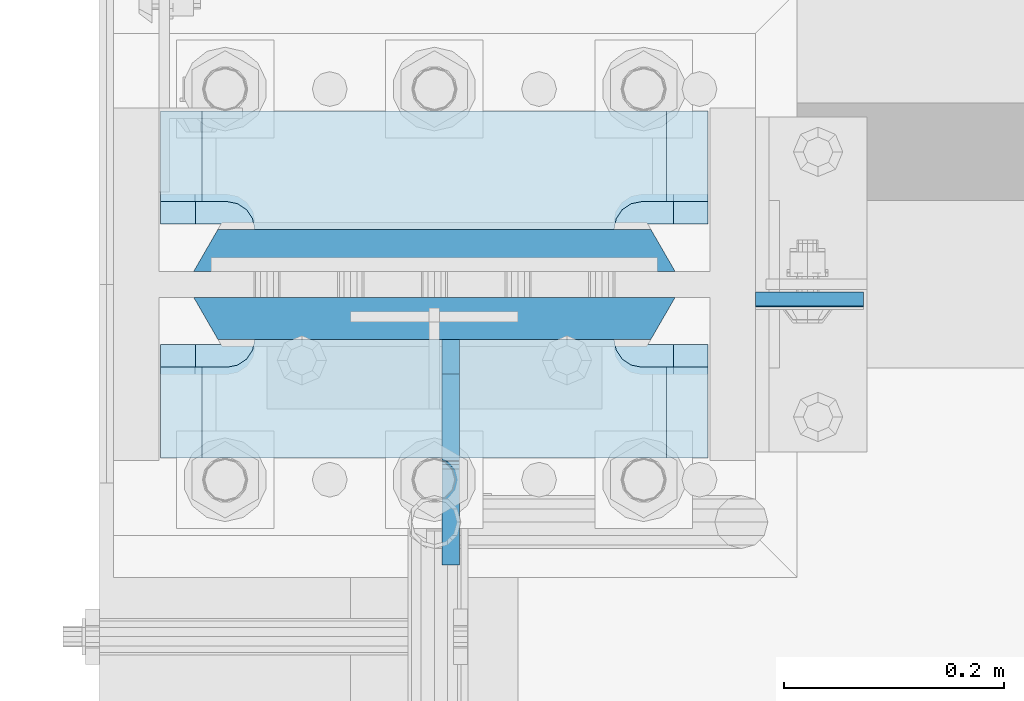
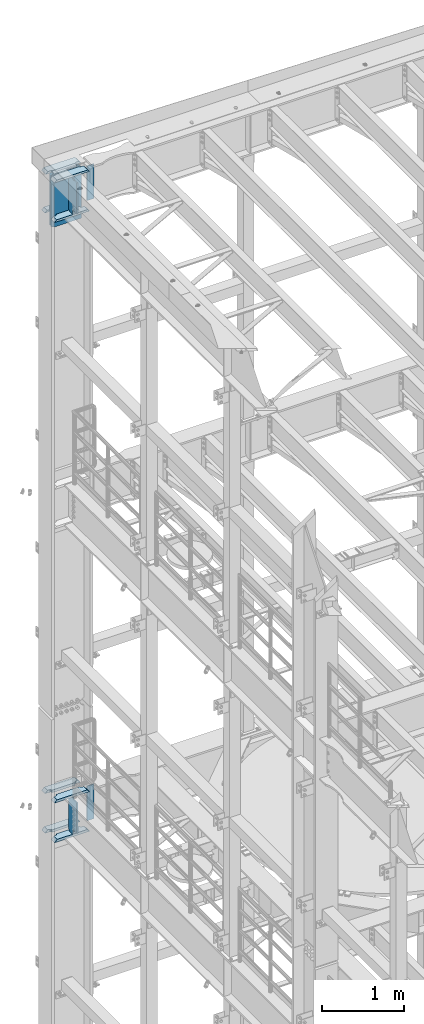
# One storey, part 1772 of 1876: 14 plates, 2 elements without a shape of their own.
"""IFC2X3 building model written with IfcOpenShell, lengths in millimetres."""

import ifcopenshell
import ifcopenshell.guid

model = None  # the IFC model being written
_history = None  # IfcOwnerHistory: only IFC2X3 demands one
_inside = {}  # id of a spatial element -> (the spatial element, [elements in it])
_under = {}  # id of a project, library or spatial element -> (it, [spatial elements below it])
_declared = {}  # id of a project -> (the project, [libraries it declares])
_typed = {}  # id of a type object -> (the type object, [elements of that type])
_made_of = {}  # id of a material, layer set ... -> (it, [elements and type objects made of it])


def new_model(schema):
    """Start an empty IFC model of exactly this schema.

    Asked for "IFC4X3", IfcOpenShell would pick the latest addendum, in which some entities
    have other attributes; the version numbers below select the first issue.
    IFC2X3 requires an IfcOwnerHistory on every rooted entity: one is made here for all.
    """
    global model, _history
    if schema == "IFC4X3":
        model = ifcopenshell.file(schema_version=(4, 3, 0, 0))
    else:
        model = ifcopenshell.file(schema=schema)
    _inside.clear()
    _under.clear()
    _declared.clear()
    _typed.clear()
    _made_of.clear()
    _history = None
    if model.schema == "IFC2X3":
        org = make("IfcOrganization", Name="unknown")
        user = make(
            "IfcPersonAndOrganization",
            ThePerson=make("IfcPerson", FamilyName="unknown"),
            TheOrganization=org,
        )
        app = make(
            "IfcApplication",
            ApplicationDeveloper=org,
            Version="unknown",
            ApplicationFullName="unknown",
            ApplicationIdentifier="unknown",
        )
        _history = make(
            "IfcOwnerHistory",
            OwningUser=user,
            OwningApplication=app,
            ChangeAction="ADDED",
            CreationDate=0,
        )
    return model


def make(cls, **values):
    """One entity of the class cls with the attributes given. An attribute that is None is left unset."""
    return model.create_entity(
        cls, **{name: value for name, value in values.items() if value is not None}
    )


def rooted(cls, **values):
    """An entity with a GlobalId (a new one), such as an element, a storey or a relation."""
    return make(cls, GlobalId=ifcopenshell.guid.new(), OwnerHistory=_history, **values)


def si_unit(unit_type, name, prefix=None):
    """IfcSIUnit, for example si_unit("LENGTHUNIT", "METRE", prefix="MILLI")."""
    return make("IfcSIUnit", UnitType=unit_type, Prefix=prefix, Name=name)


def assignment(units):
    """IfcUnitAssignment: the units of a project."""
    return None if units is None else make("IfcUnitAssignment", Units=units)


def point(xyz):
    """IfcCartesianPoint."""
    return None if xyz is None else make("IfcCartesianPoint", Coordinates=xyz)


def direction(xyz):
    """IfcDirection."""
    return None if xyz is None else make("IfcDirection", DirectionRatios=xyz)


def frame(location, z_axis=None, x_axis=None):
    """IfcAxis2Placement3D, a coordinate frame: its origin and axes. An axis left out is left unset."""
    return make(
        "IfcAxis2Placement3D",
        Location=point(location),
        Axis=direction(z_axis),
        RefDirection=direction(x_axis),
    )


def origin_with_axes():
    """The frame at (0, 0, 0) with the z axis (0, 0, 1) and the x axis (1, 0, 0) written out."""
    return frame((0.0, 0.0, 0.0), z_axis=(0.0, 0.0, 1.0), x_axis=(1.0, 0.0, 0.0))


def place(relative_to, where):
    """IfcLocalPlacement: puts the frame where relative to a parent placement (None: the world)."""
    return make(
        "IfcLocalPlacement", PlacementRelTo=relative_to, RelativePlacement=where
    )


def context(
    kind, dimensions, precision=None, world=None, true_north=None, identifier=None
):
    """IfcGeometricRepresentationContext, for example the 3D "Model" context."""
    return make(
        "IfcGeometricRepresentationContext",
        ContextIdentifier=identifier,
        ContextType=kind,
        CoordinateSpaceDimension=dimensions,
        Precision=precision,
        WorldCoordinateSystem=world,
        TrueNorth=true_north,
    )


def subcontext(parent, identifier, kind, view, scale=None):
    """IfcGeometricRepresentationSubContext, for example "Body" below "Model"."""
    return make(
        "IfcGeometricRepresentationSubContext",
        ContextIdentifier=identifier,
        ContextType=kind,
        ParentContext=parent,
        TargetScale=scale,
        TargetView=view,
    )


def project(units=None, contexts=None):
    """IfcProject with its units and contexts."""
    return rooted(
        "IfcProject",
        Name="project",
        RepresentationContexts=contexts,
        UnitsInContext=assignment(units),
    )


def spatial(cls, under=None, at=None, **own):
    """A site, building, storey or space (cls), placed at a placement, below another one or the project."""
    s = rooted(cls, ObjectPlacement=at, **own)
    if under is not None:
        _under.setdefault(under.id(), (under, []))[1].append(s)
    return s


def faces_of(points, faces, orient=None, outer=None):
    """IfcFace entities. A face is a list of loops; a loop is a list of indices into points, from 0.

    orient and outer hold one flag for each loop. By default every Orientation is true, the
    first loop of a face is its IfcFaceOuterBound and the others are IfcFaceBound.
    """
    made = []
    for i, loops in enumerate(faces):
        bounds = []
        for j, loop in enumerate(loops):
            is_outer = j == 0 if outer is None else outer[i][j]
            bounds.append(
                make(
                    "IfcFaceOuterBound" if is_outer else "IfcFaceBound",
                    Bound=make("IfcPolyLoop", Polygon=[points[k] for k in loop]),
                    Orientation=True if orient is None else orient[i][j],
                )
            )
        made.append(make("IfcFace", Bounds=bounds))
    return made


def faceted_brep(points, faces, orient=None, outer=None, voids=None):
    """IfcFacetedBrep: a solid bounded by flat faces; with voids (closed shells), ...WithVoids."""
    shared = [point(p) for p in points]
    hull = make("IfcClosedShell", CfsFaces=faces_of(shared, faces, orient, outer))
    if voids is None:
        return make("IfcFacetedBrep", Outer=hull)
    return make(
        "IfcFacetedBrepWithVoids",
        Outer=hull,
        Voids=[
            make(cls, CfsFaces=faces_of(shared, fs, o, b)) for cls, fs, o, b in voids
        ],
    )


def shape(context_of_items, identifier, shape_type, items):
    """IfcShapeRepresentation: the items that make up one representation, for example the "Body"."""
    return make(
        "IfcShapeRepresentation",
        ContextOfItems=context_of_items,
        RepresentationIdentifier=identifier,
        RepresentationType=shape_type,
        Items=items,
    )


def material(Name=None, Category=None):
    """IfcMaterial."""
    return make("IfcMaterial", Name=Name, Category=Category)


def made_of(thing, what):
    """Note that an element or type object is made of a material, layer set ...; save() writes the relation."""
    if what is not None:
        _made_of.setdefault(what.id(), (what, []))[1].append(thing)
    return thing


def type_object(cls, material=None, **own):
    """A type object (cls), such as IfcWallType, which elements share."""
    return made_of(rooted(cls, **own), material)


def element(
    cls,
    number,
    at=None,
    inside=None,
    cuts=None,
    type_object=None,
    material=None,
    context=None,
    identifier="Body",
    shape_type=None,
    held_by="IfcProductDefinitionShape",
    body=None,
    shapes=None,
    **own,
):
    """One element of the class cls, such as IfcWall. Its Tag is "e" and its number.

    at: its placement. inside: the storey or other place that contains it. cuts: it is an
    opening in that element (IfcRelVoidsElement). A single representation is given by context,
    identifier, shape_type and body (its items); several are given by shapes. held_by: the class
    of the entity that holds the representations. save() writes the other relations.
    """
    e = rooted(cls, Tag="e%d" % number, ObjectPlacement=at, **own)
    if body is not None:
        shapes = [shape(context, identifier, shape_type, body)]
    if shapes is not None:
        e.Representation = make(held_by, Representations=shapes)
    if inside is not None:
        _inside.setdefault(inside.id(), (inside, []))[1].append(e)
    if cuts is not None:
        rooted(
            "IfcRelVoidsElement", RelatingBuildingElement=cuts, RelatedOpeningElement=e
        )
    if type_object is not None:
        _typed.setdefault(type_object.id(), (type_object, []))[1].append(e)
    return made_of(e, material)


def aggregate(whole, parts):
    """IfcRelAggregates: a whole, such as a stair, and the parts it consists of."""
    return rooted("IfcRelAggregates", RelatingObject=whole, RelatedObjects=parts)


def save(model, path):
    """Write the relations noted so far, then the file.

    IfcRelAggregates (storeys below a building ...), IfcRelContainedInSpatialStructure (elements
    in a storey), IfcRelDefinesByType, IfcRelAssociatesMaterial and IfcRelDeclares: one each for
    every whole, place, type object, material and project.
    """
    for whole, parts in _under.values():
        aggregate(whole, parts)
    for where, things in _inside.values():
        rooted(
            "IfcRelContainedInSpatialStructure",
            RelatedElements=things,
            RelatingStructure=where,
        )
    for kind, things in _typed.values():
        rooted("IfcRelDefinesByType", RelatedObjects=things, RelatingType=kind)
    for what, things in _made_of.values():
        rooted("IfcRelAssociatesMaterial", RelatedObjects=things, RelatingMaterial=what)
    for by, libraries in _declared.values():
        rooted("IfcRelDeclares", RelatingContext=by, RelatedDefinitions=libraries)
    model.write(path)


model = new_model("IFC2X3")

# Units and contexts
model_context = context("Model", 3, precision=1e-05, world=origin_with_axes())
body_context = subcontext(model_context, "Body", "Model", "MODEL_VIEW")
ifc_project = project(units=[si_unit("LENGTHUNIT", "METRE", prefix="MILLI"), si_unit("AREAUNIT", "SQUARE_METRE"), si_unit("VOLUMEUNIT", "CUBIC_METRE"), si_unit("MASSUNIT", "GRAM", prefix="KILO"), si_unit("TIMEUNIT", "SECOND"), si_unit("PLANEANGLEUNIT", "RADIAN"), si_unit("SOLIDANGLEUNIT", "STERADIAN"), si_unit("THERMODYNAMICTEMPERATUREUNIT", "DEGREE_CELSIUS"), si_unit("LUMINOUSINTENSITYUNIT", "LUMEN")], contexts=[model_context])

# Site, building, storey
site_placement = place(None, origin_with_axes())
site = spatial("IfcSite", under=ifc_project, at=site_placement, CompositionType="ELEMENT")
building_placement = place(site_placement, origin_with_axes())
building = spatial("IfcBuilding", under=site, at=building_placement, Name="Undefined", CompositionType="ELEMENT")
storey_placement = place(building_placement, origin_with_axes())
storey = spatial("IfcBuildingStorey", under=building, at=storey_placement, Name="Undefined", CompositionType="ELEMENT", Elevation=0.0)

# Assembly, plate
assembly_1_placement = place(storey_placement, origin_with_axes())
assembly_1 = element("IfcElementAssembly", 1, at=assembly_1_placement, inside=storey, Name="COLUMN", AssemblyPlace="NOTDEFINED", PredefinedType="RIGID_FRAME")
ifc_material_1 = material(Name="STEEL/A572-50")
plate_type_1 = type_object("IfcPlateType", PredefinedType="NOTDEFINED")
plate_1_placement = place(assembly_1_placement, frame((292.1, 13702.5069998741, 22501.225), z_axis=(1.0, 0.0, 0.0), x_axis=(0.0, 0.0, -1.0)))
plate_1 = element("IfcPlate", 2, at=plate_1_placement, type_object=plate_type_1, material=ifc_material_1, Name="PLATE", context=body_context, shape_type="Brep", body=[
    faceted_brep([(0.0, -6.35000000000036, 0.0), (0.0, -6.34999999999991, 98.4250030517578), (0.0, 6.34999999999991, 98.4250030517578), (0.0, 6.35000000000036, 0.0), (514.349975585938, -6.35000000000036, 98.4250030517578), (514.349975585938, 6.35000000000036, 98.4250030517578), (514.349975585938, -6.35000000000036, 0.0), (514.349975585938, 6.35000000000036, 0.0)], [[[0, 1, 2, 3]], [[1, 4, 5, 2]], [[4, 6, 7, 5]], [[6, 0, 3, 7]], [[5, 7, 3, 2]], [[6, 4, 1, 0]]]),
])

assembly_2_placement = place(storey_placement, origin_with_axes())
assembly_2 = element("IfcElementAssembly", 3, at=assembly_2_placement, inside=storey, Name="COLUMN", AssemblyPlace="NOTDEFINED", PredefinedType="RIGID_FRAME")
plate_2_placement = place(assembly_2_placement, frame((292.1, 13701.7130002022, 13254.0375), z_axis=(1.0, 0.0, 0.0), x_axis=(0.0, 0.0, -1.0)))
plate_2 = element("IfcPlate", 4, at=plate_2_placement, type_object=plate_type_1, material=ifc_material_1, Name="PLATE", context=body_context, shape_type="Brep", body=[
    faceted_brep([(0.0, -6.35000000000036, 0.0), (0.0, -6.34999999999991, 98.4250030517578), (0.0, 6.34999999999991, 98.4250030517578), (0.0, 6.35000000000036, 0.0), (517.525024414062, -6.35000000000036, 98.4250030517578), (517.525024414062, 6.35000000000036, 98.4250030517578), (517.525024414062, -6.35000000000036, 0.0), (517.525024414062, 6.35000000000036, 0.0)], [[[0, 1, 2, 3]], [[1, 4, 5, 2]], [[4, 6, 7, 5]], [[6, 0, 3, 7]], [[5, 7, 3, 2]], [[6, 4, 1, 0]]]),
])

# Plate
ifc_material_2 = material(Name="STEEL/A572-GR.50")
plate_type_2 = type_object("IfcPlateType", PredefinedType="NOTDEFINED")
plate_3_placement = place(assembly_1_placement, frame((219.075, 13685.04375, 22523.45), z_axis=(-1.0, 0.0, 0.0), x_axis=(0.0, 0.0, -1.0)))
plate_3 = element("IfcPlate", 5, at=plate_3_placement, type_object=plate_type_2, material=ifc_material_2, Name="PLATE", context=body_context, shape_type="Brep", body=[
    faceted_brep([(0.0, 19.0500000000002, 416.152954742277), (0.0, -19.0500000000002, 438.149993896484), (742.950012207031, -19.0500000000002, 438.149993896484), (742.950012207031, 19.0500000000002, 416.152954742277), (742.950012207031, 19.0500000000002, 21.9970452577325), (0.0, 19.0500000000002, 21.9970452577367), (0.0, -19.0500000000002, 0.0), (742.950012207031, -19.0500000000002, 0.0)], [[[0, 1, 2, 3]], [[0, 3, 4, 5]], [[1, 0, 5, 6]], [[2, 1, 6, 7]], [[3, 2, 7, 4]], [[6, 5, 4, 7]]]),
])

plate_4_placement = place(assembly_1_placement, frame((219.075, 13746.95625, 22523.45), z_axis=(-1.0, 0.0, 0.0), x_axis=(0.0, 0.0, -1.0)))
plate_4 = element("IfcPlate", 6, at=plate_4_placement, type_object=plate_type_2, material=ifc_material_2, Name="PLATE", context=body_context, shape_type="Brep", body=[
    faceted_brep([(0.0, -19.0500000000002, 416.152954749452), (742.950012207031, -19.0500000000002, 416.152954749372), (742.950012207031, 19.0500000000002, 438.149993896484), (0.0, 19.0500000000002, 438.149993896484), (742.950012207031, -19.0500000000002, 21.9970452506512), (742.950012207031, 19.0500000000002, 0.0), (-9.09494701772928e-13, 19.05, -1.81898940354586e-12), (0.0, -19.0500000000002, 21.9970452506512)], [[[0, 1, 2, 3]], [[2, 1, 4, 5]], [[3, 2, 5, 6]], [[0, 3, 6, 7]], [[1, 0, 7, 4]], [[6, 5, 4, 7]]]),
])

plate_type_3 = type_object("IfcPlateType", PredefinedType="NOTDEFINED")
plate_5_placement = place(assembly_1_placement, frame((-249.2375, 13766.00625, 21948.775012207), z_axis=(1.0, 0.0, 0.0), x_axis=(0.0, 1.0, 0.0)))
plate_5 = element("IfcPlate", 7, at=plate_5_placement, type_object=plate_type_3, material=ifc_material_1, Name="PLATE", context=body_context, shape_type="Brep", body=[
    faceted_brep([(107.949996948242, -15.875, 498.475006103516), (107.949996948242, 15.875, 467.025007631571), (25.3999996185303, 15.875, 467.025007631571), (25.3999996185303, -15.875, 498.475006103516), (23.4665397733534, -15.875, 428.429848211837), (25.3999996185303, -15.875, 438.150007247925), (25.3999996185303, 15.875, 438.150007247925), (23.4665397733534, 15.875, 428.429848211837), (17.9605119723965, -15.875, 420.189495275529), (17.9605119723965, 15.875, 420.189495275529), (9.72015903608917, -15.875, 414.683467474573), (9.72015903608917, 15.875, 414.683467474573), (0.0, -15.875, 412.750007629395), (0.0, 15.875, 412.750007629395), (0.0, -15.875, 85.7249984741211), (0.0, 15.875, 85.7249984741211), (9.72015903609099, -15.875, 83.7915386289454), (9.72015903609099, 15.875, 83.7915386289454), (17.9605119723983, -15.875, 78.2855108279892), (17.9605119723983, 15.875, 78.2855108279892), (23.4665397733552, -15.875, 70.0451578916817), (23.4665397733552, 15.875, 70.0451578916817), (25.3999996185303, -15.875, 60.3249988555908), (25.3999996185303, 15.875, 60.3249988555908), (25.3999996185303, 15.875, 31.449998471945), (25.3999996185303, -15.875, 0.0), (107.949996948242, 15.875, 31.449998471945), (107.949996948242, -15.875, 0.0)], [[[0, 1, 2, 3]], [[4, 5, 6, 7]], [[8, 4, 7, 9]], [[10, 8, 9, 11]], [[12, 10, 11, 13]], [[14, 12, 13, 15]], [[16, 14, 15, 17]], [[18, 16, 17, 19]], [[20, 18, 19, 21]], [[22, 20, 21, 23]], [[22, 23, 24, 25]], [[26, 27, 25, 24]], [[5, 4, 8, 10, 12, 14, 16, 18, 20, 22, 25, 27, 0, 3]], [[6, 5, 3, 2]], [[26, 24, 23, 21, 19, 17, 15, 13, 11, 9, 7, 6, 2, 1]], [[27, 26, 1, 0]]]),
])

plate_6_placement = place(assembly_1_placement, frame((-249.2375, 13558.04375, 21948.775012207), z_axis=(1.0, 0.0, 0.0), x_axis=(0.0, 1.0, 0.0)))
plate_6 = element("IfcPlate", 8, at=plate_6_placement, type_object=plate_type_3, material=ifc_material_1, Name="PLATE", context=body_context, shape_type="Brep", body=[
    faceted_brep([(82.5499973297119, -15.875, 498.475006103516), (82.5499973297119, 15.875, 467.025007631571), (0.0, 15.875, 467.025007631571), (0.0, -15.875, 498.475006103516), (82.5499973297119, 15.875, 31.449998471945), (82.5499973297119, -15.875, 0.0), (0.0, -15.875, 0.0), (0.0, 15.875, 31.449998471945), (82.5499973297119, 15.875, 60.3249988555908), (82.5499973297119, -15.875, 60.3249988555908), (84.4834571748879, -15.875, 70.045157891682), (84.4834571748879, 15.875, 70.045157891682), (89.9894849758439, -15.875, 78.2855108279893), (89.9894849758439, 15.875, 78.2855108279893), (98.2298379121512, -15.875, 83.7915386289454), (98.2298379121512, 15.875, 83.7915386289454), (107.949996948242, -15.875, 85.7249984741211), (107.949996948242, 15.875, 85.7249984741211), (107.949996948242, -15.875, 412.750007629395), (107.949996948242, 15.875, 412.750007629395), (98.2298379121512, -15.875, 414.68346747457), (98.2298379121512, 15.875, 414.68346747457), (89.989484975843, -15.875, 420.189495275526), (89.989484975843, 15.875, 420.189495275526), (84.483457174887, -15.875, 428.429848211834), (84.483457174887, 15.875, 428.429848211834), (82.5499973297119, -15.875, 438.150007247925), (82.5499973297119, 15.875, 438.150007247925)], [[[0, 1, 2, 3]], [[4, 5, 6, 7]], [[8, 9, 5, 4]], [[10, 9, 8, 11]], [[12, 10, 11, 13]], [[14, 12, 13, 15]], [[16, 14, 15, 17]], [[18, 16, 17, 19]], [[20, 18, 19, 21]], [[22, 20, 21, 23]], [[24, 22, 23, 25]], [[26, 24, 25, 27]], [[6, 5, 9, 10, 12, 14, 16, 18, 20, 22, 24, 26, 0, 3]], [[7, 6, 3, 2]], [[27, 25, 23, 21, 19, 17, 15, 13, 11, 8, 4, 7, 2, 1]], [[26, 27, 1, 0]]]),
])

ifc_material_3 = material(Name="STEEL/A36")
plate_type_4 = type_object("IfcPlateType", PredefinedType="NOTDEFINED")
plate_7_placement = place(assembly_1_placement, frame((15.0812500000025, 13665.99375, 22523.45), z_axis=(0.0, -1.0, 0.0), x_axis=(0.0, 0.0, -1.0)))
plate_7 = element("IfcPlate", 9, at=plate_7_placement, type_object=plate_type_4, material=ifc_material_3, Name="PLATE", context=body_context, shape_type="Brep", body=[
    faceted_brep([(488.949999999997, -7.93749999999998, 205.581253456207), (488.949999999997, -7.93749999999998, 120.649999809266), (488.949999999997, 7.93749999999999, 120.649999809266), (488.949999999997, 7.93749999999999, 205.581253051758), (489.916729922585, -7.93749999999998, 115.78992029122), (489.916729922585, 7.93749999999999, 115.78992029122), (492.669743823062, -7.93749999999998, 111.669743823067), (492.669743823062, 7.93749999999999, 111.669743823067), (496.789920291216, -7.93749999999998, 108.916729922588), (496.789920291216, 7.93749999999999, 108.916729922588), (501.649999809262, -7.93749999999998, 107.950000000001), (501.649999809262, 7.93749999999999, 107.950000000001), (558.799987792969, -7.93749999999998, 107.950000000001), (558.799987792969, 7.93749999999999, 107.950000000001), (31.7499984741225, -7.93749999999998, 205.581256103516), (31.7499984741225, 7.93749999999999, 205.581253051758), (31.7499984741225, 7.93749999999999, 120.649999809266), (31.7499984741225, -7.93749999999998, 120.649999809266), (30.783268551535, 7.93749999999999, 115.78992029122), (30.783268551535, -7.93749999999998, 115.78992029122), (28.0302546510575, 7.93749999999999, 111.669743823067), (28.0302546510575, -7.93749999999998, 111.669743823067), (23.9100781829038, 7.93749999999999, 108.916729922588), (23.9100781829038, -7.93749999999998, 108.916729922588), (19.0499986648574, 7.93749999999999, 107.950000000001), (19.0499986648574, -7.93749999999998, 107.950000000001), (0.0, 7.93749999999999, 107.950000000001), (0.0, -7.93749999999998, 107.950000000001), (0.0, 7.93749999999999, 31.75), (0.0, -7.93749999999998, 31.75), (31.75, -7.93749999999998, 0.0), (31.75, 7.93749999999999, 0.0), (527.049987792969, -7.93749999999998, 0.0), (527.049987792969, 7.93749999999999, 0.0), (558.799987792969, -7.93749999999998, 31.75), (558.799987792969, 7.93749999999999, 31.75)], [[[0, 1, 2, 3]], [[4, 5, 2, 1]], [[6, 7, 5, 4]], [[8, 9, 7, 6]], [[10, 11, 9, 8]], [[12, 13, 11, 10]], [[14, 15, 16, 17]], [[17, 16, 18, 19]], [[19, 18, 20, 21]], [[21, 20, 22, 23]], [[23, 22, 24, 25]], [[25, 24, 26, 27]], [[28, 29, 27, 26]], [[30, 29, 28, 31]], [[32, 30, 31, 33]], [[34, 32, 33, 35]], [[8, 6, 4, 1, 0, 14, 17, 19, 21, 23, 25, 27, 29, 30, 32, 34, 12, 10]], [[15, 14, 0, 3]], [[35, 33, 31, 28, 26, 24, 22, 20, 18, 16, 15, 3, 2, 5, 7, 9, 11, 13]], [[34, 35, 13, 12]]]),
])

plate_8_placement = place(assembly_2_placement, frame((15.080500125885, 13665.99375, 13271.5), z_axis=(0.0, -1.0, 0.0), x_axis=(0.0, 0.0, -1.0)))
plate_8 = element("IfcPlate", 10, at=plate_8_placement, type_object=plate_type_4, material=ifc_material_3, Name="PLATE", context=body_context, shape_type="Brep", body=[
    faceted_brep([(482.600012207031, -7.9375, 205.581252647308), (482.600012207031, -7.9375, 123.031246757508), (482.600012207031, 7.9375, 123.031246757508), (482.600012207031, 7.9375, 205.581253051758), (483.566742129618, -7.9375, 118.171167239462), (483.566742129618, 7.9375, 118.171167239462), (486.319756030096, -7.9375, 114.050990771309), (486.319756030096, 7.9375, 114.050990771309), (490.43993249825, -7.9375, 111.29797687083), (490.43993249825, 7.9375, 111.29797687083), (495.300012016296, -7.9375, 110.331246948243), (495.300012016296, 7.9375, 110.331246948243), (552.450012207031, -7.9375, 110.331246948243), (552.450012207031, 7.9375, 110.331246948243), (25.3999996185303, -7.9375, 205.581249999999), (25.3999996185303, 7.9375, 205.581253051758), (25.3999996185303, 7.9375, 123.031249809264), (25.3999996185303, -7.9375, 123.031249809264), (24.4332696959427, 7.9375, 118.171170291219), (24.4332696959427, -7.9375, 118.171170291219), (21.6802557954652, 7.9375, 114.050993823065), (21.6802557954652, -7.9375, 114.050993823065), (17.5600793273115, 7.9375, 111.297979922587), (17.5600793273115, -7.9375, 111.297979922587), (12.6999998092651, 7.9375, 110.331249999999), (12.6999998092651, -7.9375, 110.331249999999), (0.0, 7.9375, 110.33125), (0.0, -7.9375, 110.33125), (0.0, 7.93749999999999, 31.75), (0.0, -7.93749999999998, 31.75), (31.75, -7.93749999999998, 0.0), (31.75, 7.93749999999999, 0.0), (520.700012207031, -7.9375, 0.0), (520.700012207031, 7.9375, 0.0), (552.450012207031, -7.9375, 31.75), (552.450012207031, 7.9375, 31.75)], [[[0, 1, 2, 3]], [[4, 5, 2, 1]], [[6, 7, 5, 4]], [[8, 9, 7, 6]], [[10, 11, 9, 8]], [[12, 13, 11, 10]], [[14, 15, 16, 17]], [[17, 16, 18, 19]], [[19, 18, 20, 21]], [[21, 20, 22, 23]], [[23, 22, 24, 25]], [[25, 24, 26, 27]], [[28, 29, 27, 26]], [[30, 29, 28, 31]], [[32, 30, 31, 33]], [[34, 32, 33, 35]], [[8, 6, 4, 1, 0, 14, 17, 19, 21, 23, 25, 27, 29, 30, 32, 34, 12, 10]], [[15, 14, 0, 3]], [[35, 33, 31, 28, 26, 24, 22, 20, 18, 16, 15, 3, 2, 5, 7, 9, 11, 13]], [[34, 35, 13, 12]]]),
])

plate_type_5 = type_object("IfcPlateType", PredefinedType="NOTDEFINED")
plate_9_placement = place(assembly_2_placement, frame((-249.2375, 13766.00625, 12699.999987793), z_axis=(1.0, 0.0, 0.0), x_axis=(0.0, 1.0, 0.0)))
plate_9 = element("IfcPlate", 11, at=plate_9_placement, type_object=plate_type_5, material=ifc_material_1, Name="PLATE", context=body_context, shape_type="Brep", body=[
    faceted_brep([(107.949996948242, -19.0499999999993, 498.475006103516), (107.949996948242, 19.0499999999993, 460.675005342751), (25.3999996185303, 19.0499999999993, 460.675005342751), (25.3999996185303, -19.0499999999993, 498.475006103516), (23.4665397733534, -19.0499999999993, 428.429848211837), (25.3999996185303, -19.0499999999993, 438.150007247925), (25.3999996185303, 19.0499999999993, 438.150007247925), (23.4665397733534, 19.0499999999993, 428.429848211837), (17.9605119723965, -19.0499999999993, 420.189495275529), (17.9605119723965, 19.0499999999993, 420.189495275529), (9.72015903608917, -19.0499999999993, 414.683467474573), (9.72015903608917, 19.0499999999993, 414.683467474573), (0.0, -19.0499999999993, 412.750007629395), (0.0, 19.0499999999993, 412.750007629395), (0.0, -19.0499999999993, 85.7249984741211), (0.0, 19.0499999999993, 85.7249984741211), (9.72015903609099, -19.0499999999993, 83.7915386289451), (9.72015903609099, 19.0499999999993, 83.7915386289451), (17.9605119723983, -19.0499999999993, 78.2855108279891), (17.9605119723983, 19.0499999999993, 78.2855108279891), (23.4665397733552, -19.0499999999993, 70.0451578916818), (23.4665397733552, 19.0499999999993, 70.0451578916818), (25.3999996185303, -19.0499999999993, 60.3249988555908), (25.3999996185303, 19.0499999999993, 60.3249988555908), (25.3999996185303, 19.0499999999993, 37.8000007607643), (25.3999996185303, -19.0499999999993, 0.0), (107.949996948242, 19.0499999999993, 37.8000007607643), (107.949996948242, -19.0499999999993, 0.0)], [[[0, 1, 2, 3]], [[4, 5, 6, 7]], [[8, 4, 7, 9]], [[10, 8, 9, 11]], [[12, 10, 11, 13]], [[14, 12, 13, 15]], [[16, 14, 15, 17]], [[18, 16, 17, 19]], [[20, 18, 19, 21]], [[22, 20, 21, 23]], [[22, 23, 24, 25]], [[26, 27, 25, 24]], [[5, 4, 8, 10, 12, 14, 16, 18, 20, 22, 25, 27, 0, 3]], [[6, 5, 3, 2]], [[26, 24, 23, 21, 19, 17, 15, 13, 11, 9, 7, 6, 2, 1]], [[27, 26, 1, 0]]]),
])

plate_10_placement = place(assembly_2_placement, frame((-249.2375, 13766.00625, 13290.55), z_axis=(1.0, 0.0, 0.0), x_axis=(0.0, 1.0, 0.0)))
plate_10 = element("IfcPlate", 12, at=plate_10_placement, type_object=plate_type_5, material=ifc_material_1, Name="PLATE", context=body_context, shape_type="Brep", body=[
    faceted_brep([(107.949996948242, -19.0499999999993, 498.475006103516), (107.949996948242, 19.0499999999993, 460.675005342751), (25.3999996185303, 19.0499999999993, 460.675005342751), (25.3999996185303, -19.0499999999993, 498.475006103516), (23.4665397733534, -19.0499999999993, 428.429848211837), (25.3999996185303, -19.0499999999993, 438.150007247925), (25.3999996185303, 19.0499999999993, 438.150007247925), (23.4665397733534, 19.0499999999993, 428.429848211837), (17.9605119723965, -19.0499999999993, 420.189495275529), (17.9605119723965, 19.0499999999993, 420.189495275529), (9.72015903608917, -19.0499999999993, 414.683467474573), (9.72015903608917, 19.0499999999993, 414.683467474573), (0.0, -19.0499999999993, 412.750007629395), (0.0, 19.0499999999993, 412.750007629395), (0.0, -19.0499999999993, 85.7249984741211), (0.0, 19.0499999999993, 85.7249984741211), (9.72015903609099, -19.0499999999993, 83.7915386289451), (9.72015903609099, 19.0499999999993, 83.7915386289451), (17.9605119723983, -19.0499999999993, 78.2855108279891), (17.9605119723983, 19.0499999999993, 78.2855108279891), (23.4665397733552, -19.0499999999993, 70.0451578916818), (23.4665397733552, 19.0499999999993, 70.0451578916818), (25.3999996185303, -19.0499999999993, 60.3249988555908), (25.3999996185303, 19.0499999999993, 60.3249988555908), (25.3999996185303, 19.0499999999993, 37.8000007607643), (25.3999996185303, -19.0499999999993, 0.0), (107.949996948242, 19.0499999999993, 37.8000007607643), (107.949996948242, -19.0499999999993, 0.0)], [[[0, 1, 2, 3]], [[4, 5, 6, 7]], [[8, 4, 7, 9]], [[10, 8, 9, 11]], [[12, 10, 11, 13]], [[14, 12, 13, 15]], [[16, 14, 15, 17]], [[18, 16, 17, 19]], [[20, 18, 19, 21]], [[22, 20, 21, 23]], [[22, 23, 24, 25]], [[26, 27, 25, 24]], [[5, 4, 8, 10, 12, 14, 16, 18, 20, 22, 25, 27, 0, 3]], [[6, 5, 3, 2]], [[26, 24, 23, 21, 19, 17, 15, 13, 11, 9, 7, 6, 2, 1]], [[27, 26, 1, 0]]]),
])

plate_11_placement = place(assembly_2_placement, frame((-249.2375, 13558.04375, 12699.999987793), z_axis=(1.0, 0.0, 0.0), x_axis=(0.0, 1.0, 0.0)))
plate_11 = element("IfcPlate", 13, at=plate_11_placement, type_object=plate_type_5, material=ifc_material_1, Name="PLATE", context=body_context, shape_type="Brep", body=[
    faceted_brep([(82.5499973297119, -19.0499999999993, 498.475006103516), (82.5499973297119, 19.0499999999993, 460.675005342751), (0.0, 19.0499999999993, 460.675005342751), (0.0, -19.0499999999993, 498.475006103516), (82.5499973297119, 19.0499999999993, 37.8000007607643), (82.5499973297119, -19.0499999999993, 0.0), (0.0, -19.0500000000002, 0.0), (0.0, 19.0499999999993, 37.8000007607643), (82.5499973297119, 19.0499999999993, 60.3249988555908), (82.5499973297119, -19.0499999999993, 60.3249988555908), (84.4834571748879, -19.0499999999993, 70.0451578916818), (84.4834571748879, 19.0499999999993, 70.0451578916818), (89.9894849758439, -19.0499999999993, 78.2855108279891), (89.9894849758439, 19.0499999999993, 78.2855108279891), (98.2298379121512, -19.0499999999993, 83.7915386289451), (98.2298379121512, 19.0499999999993, 83.7915386289451), (107.949996948242, -19.0499999999993, 85.7249984741211), (107.949996948242, 19.0499999999993, 85.7249984741211), (107.949996948242, -19.0499999999993, 412.750007629395), (107.949996948242, 19.0499999999993, 412.750007629395), (98.2298379121512, -19.0499999999993, 414.683467474571), (98.2298379121512, 19.0499999999993, 414.683467474571), (89.989484975843, -19.0499999999993, 420.189495275526), (89.989484975843, 19.0499999999993, 420.189495275526), (84.483457174887, -19.0499999999993, 428.429848211834), (84.483457174887, 19.0499999999993, 428.429848211834), (82.5499973297119, -19.0499999999993, 438.150007247925), (82.5499973297119, 19.0499999999993, 438.150007247925)], [[[0, 1, 2, 3]], [[4, 5, 6, 7]], [[8, 9, 5, 4]], [[10, 9, 8, 11]], [[12, 10, 11, 13]], [[14, 12, 13, 15]], [[16, 14, 15, 17]], [[18, 16, 17, 19]], [[20, 18, 19, 21]], [[22, 20, 21, 23]], [[24, 22, 23, 25]], [[26, 24, 25, 27]], [[6, 5, 9, 10, 12, 14, 16, 18, 20, 22, 24, 26, 0, 3]], [[7, 6, 3, 2]], [[27, 25, 23, 21, 19, 17, 15, 13, 11, 8, 4, 7, 2, 1]], [[26, 27, 1, 0]]]),
])

plate_12_placement = place(assembly_2_placement, frame((-249.2375, 13558.04375, 13290.55), z_axis=(1.0, 0.0, 0.0), x_axis=(0.0, 1.0, 0.0)))
plate_12 = element("IfcPlate", 14, at=plate_12_placement, type_object=plate_type_5, material=ifc_material_1, Name="PLATE", context=body_context, shape_type="Brep", body=[
    faceted_brep([(82.5499973297119, -19.0499999999993, 498.475006103516), (82.5499973297119, 19.0499999999993, 460.675005342751), (0.0, 19.0499999999993, 460.675005342751), (0.0, -19.0499999999993, 498.475006103516), (82.5499973297119, 19.0499999999993, 37.8000007607643), (82.5499973297119, -19.0499999999993, 0.0), (0.0, -19.0500000000002, 0.0), (0.0, 19.0499999999993, 37.8000007607643), (82.5499973297119, 19.0499999999993, 60.3249988555908), (82.5499973297119, -19.0499999999993, 60.3249988555908), (84.4834571748879, -19.0499999999993, 70.0451578916818), (84.4834571748879, 19.0499999999993, 70.0451578916818), (89.9894849758439, -19.0499999999993, 78.2855108279891), (89.9894849758439, 19.0499999999993, 78.2855108279891), (98.2298379121512, -19.0499999999993, 83.7915386289451), (98.2298379121512, 19.0499999999993, 83.7915386289451), (107.949996948242, -19.0499999999993, 85.7249984741211), (107.949996948242, 19.0499999999993, 85.7249984741211), (107.949996948242, -19.0499999999993, 412.750007629395), (107.949996948242, 19.0499999999993, 412.750007629395), (98.2298379121512, -19.0499999999993, 414.683467474571), (98.2298379121512, 19.0499999999993, 414.683467474571), (89.989484975843, -19.0499999999993, 420.189495275526), (89.989484975843, 19.0499999999993, 420.189495275526), (84.483457174887, -19.0499999999993, 428.429848211834), (84.483457174887, 19.0499999999993, 428.429848211834), (82.5499973297119, -19.0499999999993, 438.150007247925), (82.5499973297119, 19.0499999999993, 438.150007247925)], [[[0, 1, 2, 3]], [[4, 5, 6, 7]], [[8, 9, 5, 4]], [[10, 9, 8, 11]], [[12, 10, 11, 13]], [[14, 12, 13, 15]], [[16, 14, 15, 17]], [[18, 16, 17, 19]], [[20, 18, 19, 21]], [[22, 20, 21, 23]], [[24, 22, 23, 25]], [[26, 24, 25, 27]], [[6, 5, 9, 10, 12, 14, 16, 18, 20, 22, 24, 26, 0, 3]], [[7, 6, 3, 2]], [[27, 25, 23, 21, 19, 17, 15, 13, 11, 8, 4, 7, 2, 1]], [[26, 27, 1, 0]]]),
])

aggregate(assembly_2, [plate_9, plate_10, plate_11, plate_12, plate_8, plate_2])

plate_type_6 = type_object("IfcPlateType", PredefinedType="NOTDEFINED")
plate_13_placement = place(assembly_1_placement, frame((-249.2375, 13727.90625, 22539.325), z_axis=(1.0, 0.0, 0.0), x_axis=(0.0, 1.0, 0.0)))
plate_13 = element("IfcPlate", 15, at=plate_13_placement, type_object=plate_type_6, material=ifc_material_1, Name="PLATE", context=body_context, shape_type="Brep", body=[
    faceted_brep([(35.0225766570229, -15.875, 84.7582685515335), (35.0225766570229, 15.875, 84.7582685515335), (39.1427531251766, 15.875, 82.0052546510551), (39.1427531251766, -15.875, 82.0052546510551), (41.895767025655, 15.875, 77.8850781829015), (41.895767025655, -15.875, 77.8850781829015), (42.8624969482426, 15.875, 73.024998664856), (42.8624969482426, -15.875, 73.024998664856), (42.8624969482426, 15.875, 31.7500061035162), (42.8624969482426, -15.875, 0.0), (146.050003051758, 15.875, 31.7500061035162), (146.049995422363, -15.875, 0.0), (146.050003051758, 15.875, 466.725012207031), (146.050003051758, -15.875, 498.475012207031), (42.8624969482426, 15.875, 466.725012207031), (42.8624969482426, -15.875, 498.475), (42.8624969482426, 15.875, 425.450001335144), (42.8624969482426, -15.875, 425.450001335144), (41.895767025655, 15.875, 420.589921817099), (41.895767025655, -15.875, 420.589921817099), (39.1427531251766, 15.875, 416.469745348945), (39.1427531251766, -15.875, 416.469745348945), (35.0225766570229, 15.875, 413.716731448467), (35.0225766570229, -15.875, 413.716731448467), (30.1624971389774, -15.875, 412.750001525879), (31.7500000000036, 15.875, 413.065775478188), (30.1624971389774, 14.2874971389756, 412.750001525879), (0.0, -15.875, 412.750007629395), (30.1624971389774, -15.875, 85.7249984741211), (0.0, -15.875, 85.7249984741211), (30.1624971389774, 14.2874971389756, 85.7249984741211), (31.7500000000036, 15.875, 85.4092245218126)], [[[0, 1, 2, 3]], [[3, 2, 4, 5]], [[5, 4, 6, 7]], [[7, 6, 8, 9]], [[10, 11, 9, 8]], [[11, 10, 12, 13]], [[13, 12, 14, 15]], [[16, 17, 15, 14]], [[17, 16, 18, 19]], [[19, 18, 20, 21]], [[21, 20, 22, 23]], [[24, 23, 22, 25, 26]], [[24, 26, 27]], [[28, 0, 3, 5, 7, 9, 11, 13, 15, 17, 19, 21, 23, 24, 27, 29]], [[28, 29, 30]], [[1, 0, 28, 30, 31]], [[22, 20, 18, 16, 14, 12, 10, 8, 6, 4, 2, 1, 31, 25]], [[30, 29, 27, 26, 25, 31]]]),
])

plate_14_placement = place(assembly_1_placement, frame((-249.237506103516, 13558.04375, 22539.325), z_axis=(1.0, 0.0, 0.0), x_axis=(0.0, 1.0, 0.0)))
plate_14 = element("IfcPlate", 16, at=plate_14_placement, type_object=plate_type_6, material=ifc_material_1, Name="PLATE", context=body_context, shape_type="Brep", body=[
    faceted_brep([(106.907246874825, -15.875, 82.0052546510551), (106.907246874825, 15.875, 82.0052546510551), (111.027423342978, 15.875, 84.7582685515335), (111.027423342978, -15.875, 84.7582685515335), (104.154232974346, -15.875, 77.8850781829015), (104.154232974346, 15.875, 77.8850781829015), (103.187503051759, -15.875, 73.024998664856), (103.187503051759, 15.875, 73.024998664856), (103.187503051759, -15.875, 0.0), (103.187503051759, 15.875, 31.7500061035153), (0.0, -15.875, 0.0), (0.0, 15.875, 31.75), (0.0, -15.875, 498.475006103516), (0.0, 15.875, 466.725006103516), (103.187503051759, -15.875, 498.475012207031), (103.187503051759, 15.875, 466.725012207031), (103.187503051759, -15.875, 425.450001335144), (103.187503051759, 15.875, 425.450001335144), (104.154232974346, -15.875, 420.589921817099), (104.154232974346, 15.875, 420.589921817099), (106.907246874825, -15.875, 416.469745348945), (106.907246874825, 15.875, 416.469745348945), (111.027423342978, -15.875, 413.716731448467), (111.027423342978, 15.875, 413.716731448467), (115.887502861024, -15.875, 412.750001525879), (146.050002288819, -15.875, 412.750001525879), (115.887502861024, 14.2875000396052, 412.750001525879), (114.300003053293, 15.875, 413.06577487085), (114.300003053293, 15.875, 85.4092251291504), (115.887502861024, -15.875, 85.7249984741211), (115.887502861024, 14.2875000396052, 85.7249984741211), (146.050002288819, -15.875, 85.7249984741211)], [[[0, 1, 2, 3]], [[4, 5, 1, 0]], [[6, 7, 5, 4]], [[7, 6, 8, 9]], [[9, 8, 10, 11]], [[11, 10, 12, 13]], [[14, 15, 13, 12]], [[16, 17, 15, 14]], [[18, 19, 17, 16]], [[20, 21, 19, 18]], [[22, 23, 21, 20]], [[24, 25, 26]], [[23, 22, 24, 26, 27]], [[2, 1, 5, 7, 9, 11, 13, 15, 17, 19, 21, 23, 27, 28]], [[29, 3, 2, 28, 30]], [[29, 30, 31]], [[24, 22, 20, 18, 16, 14, 12, 10, 8, 6, 4, 0, 3, 29, 31, 25]], [[30, 28, 27, 26, 25, 31]]]),
])

aggregate(assembly_1, [plate_1, plate_5, plate_6, plate_7, plate_3, plate_4, plate_13, plate_14])

save(model, "model.ifc")
